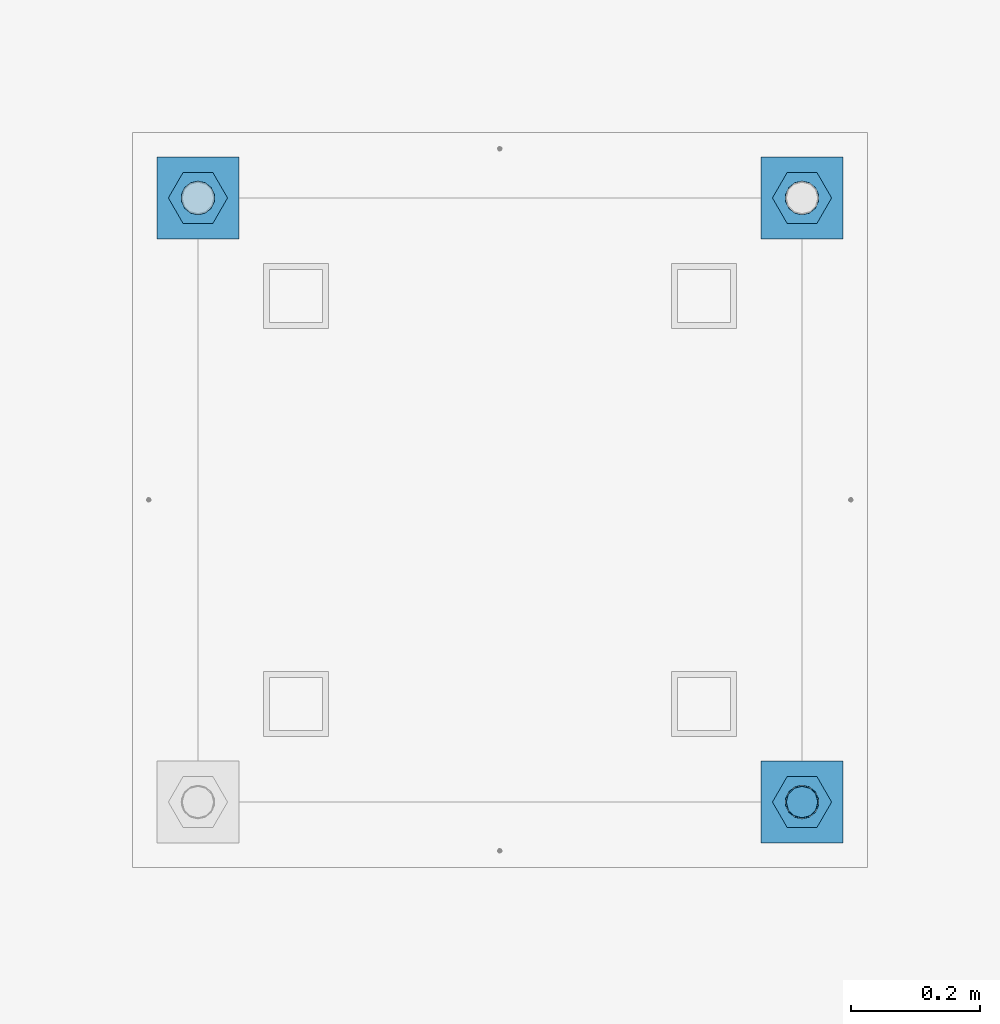
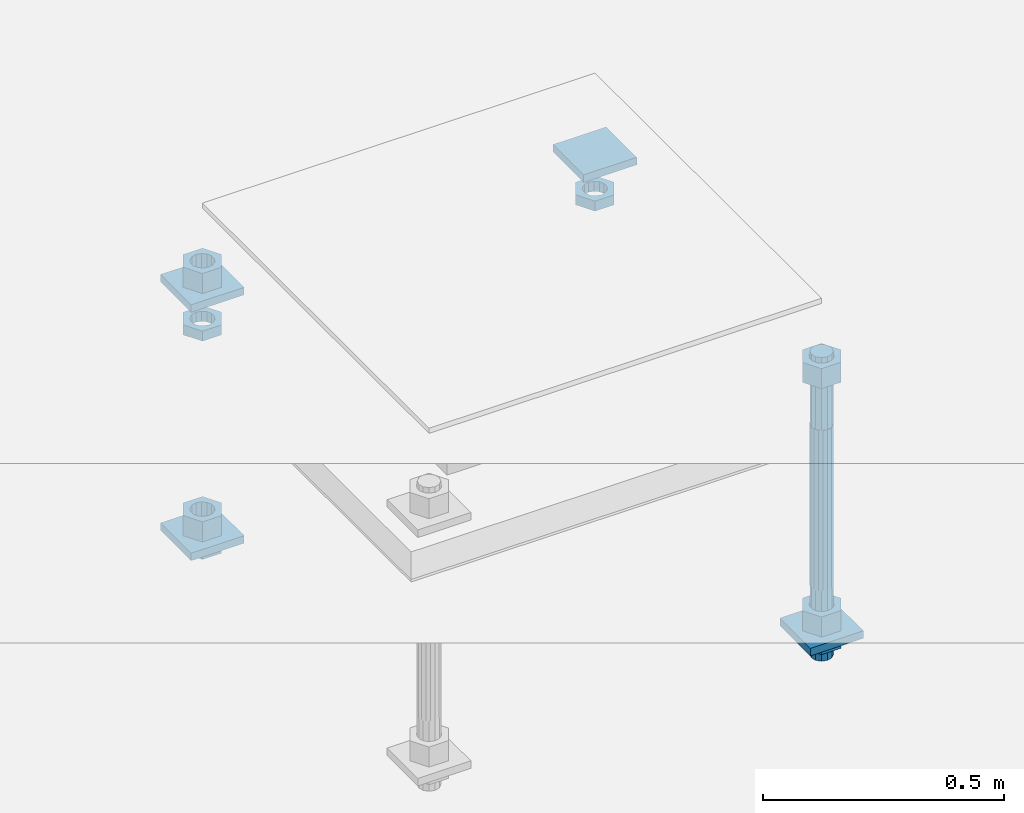
# One storey, part 2688 of 3843: 13 beams, 1 element without a shape of its own.
"""IFC2X3 building model written with IfcOpenShell, lengths in millimetres."""

import ifcopenshell
import ifcopenshell.guid

model = None  # the IFC model being written
_history = None  # IfcOwnerHistory: only IFC2X3 demands one
_inside = {}  # id of a spatial element -> (the spatial element, [elements in it])
_under = {}  # id of a project, library or spatial element -> (it, [spatial elements below it])
_declared = {}  # id of a project -> (the project, [libraries it declares])
_typed = {}  # id of a type object -> (the type object, [elements of that type])
_made_of = {}  # id of a material, layer set ... -> (it, [elements and type objects made of it])


def new_model(schema):
    """Start an empty IFC model of exactly this schema.

    Asked for "IFC4X3", IfcOpenShell would pick the latest addendum, in which some entities
    have other attributes; the version numbers below select the first issue.
    IFC2X3 requires an IfcOwnerHistory on every rooted entity: one is made here for all.
    """
    global model, _history
    if schema == "IFC4X3":
        model = ifcopenshell.file(schema_version=(4, 3, 0, 0))
    else:
        model = ifcopenshell.file(schema=schema)
    _inside.clear()
    _under.clear()
    _declared.clear()
    _typed.clear()
    _made_of.clear()
    _history = None
    if model.schema == "IFC2X3":
        org = make("IfcOrganization", Name="unknown")
        user = make(
            "IfcPersonAndOrganization",
            ThePerson=make("IfcPerson", FamilyName="unknown"),
            TheOrganization=org,
        )
        app = make(
            "IfcApplication",
            ApplicationDeveloper=org,
            Version="unknown",
            ApplicationFullName="unknown",
            ApplicationIdentifier="unknown",
        )
        _history = make(
            "IfcOwnerHistory",
            OwningUser=user,
            OwningApplication=app,
            ChangeAction="ADDED",
            CreationDate=0,
        )
    return model


def make(cls, **values):
    """One entity of the class cls with the attributes given. An attribute that is None is left unset."""
    return model.create_entity(
        cls, **{name: value for name, value in values.items() if value is not None}
    )


def rooted(cls, **values):
    """An entity with a GlobalId (a new one), such as an element, a storey or a relation."""
    return make(cls, GlobalId=ifcopenshell.guid.new(), OwnerHistory=_history, **values)


def si_unit(unit_type, name, prefix=None):
    """IfcSIUnit, for example si_unit("LENGTHUNIT", "METRE", prefix="MILLI")."""
    return make("IfcSIUnit", UnitType=unit_type, Prefix=prefix, Name=name)


def assignment(units):
    """IfcUnitAssignment: the units of a project."""
    return None if units is None else make("IfcUnitAssignment", Units=units)


def point(xyz):
    """IfcCartesianPoint."""
    return None if xyz is None else make("IfcCartesianPoint", Coordinates=xyz)


def direction(xyz):
    """IfcDirection."""
    return None if xyz is None else make("IfcDirection", DirectionRatios=xyz)


def frame(location, z_axis=None, x_axis=None):
    """IfcAxis2Placement3D, a coordinate frame: its origin and axes. An axis left out is left unset."""
    return make(
        "IfcAxis2Placement3D",
        Location=point(location),
        Axis=direction(z_axis),
        RefDirection=direction(x_axis),
    )


def origin_with_axes():
    """The frame at (0, 0, 0) with the z axis (0, 0, 1) and the x axis (1, 0, 0) written out."""
    return frame((0.0, 0.0, 0.0), z_axis=(0.0, 0.0, 1.0), x_axis=(1.0, 0.0, 0.0))


def place(relative_to, where):
    """IfcLocalPlacement: puts the frame where relative to a parent placement (None: the world)."""
    return make(
        "IfcLocalPlacement", PlacementRelTo=relative_to, RelativePlacement=where
    )


def context(
    kind, dimensions, precision=None, world=None, true_north=None, identifier=None
):
    """IfcGeometricRepresentationContext, for example the 3D "Model" context."""
    return make(
        "IfcGeometricRepresentationContext",
        ContextIdentifier=identifier,
        ContextType=kind,
        CoordinateSpaceDimension=dimensions,
        Precision=precision,
        WorldCoordinateSystem=world,
        TrueNorth=true_north,
    )


def subcontext(parent, identifier, kind, view, scale=None):
    """IfcGeometricRepresentationSubContext, for example "Body" below "Model"."""
    return make(
        "IfcGeometricRepresentationSubContext",
        ContextIdentifier=identifier,
        ContextType=kind,
        ParentContext=parent,
        TargetScale=scale,
        TargetView=view,
    )


def project(units=None, contexts=None):
    """IfcProject with its units and contexts."""
    return rooted(
        "IfcProject",
        Name="project",
        RepresentationContexts=contexts,
        UnitsInContext=assignment(units),
    )


def spatial(cls, under=None, at=None, **own):
    """A site, building, storey or space (cls), placed at a placement, below another one or the project."""
    s = rooted(cls, ObjectPlacement=at, **own)
    if under is not None:
        _under.setdefault(under.id(), (under, []))[1].append(s)
    return s


def faces_of(points, faces, orient=None, outer=None):
    """IfcFace entities. A face is a list of loops; a loop is a list of indices into points, from 0.

    orient and outer hold one flag for each loop. By default every Orientation is true, the
    first loop of a face is its IfcFaceOuterBound and the others are IfcFaceBound.
    """
    made = []
    for i, loops in enumerate(faces):
        bounds = []
        for j, loop in enumerate(loops):
            is_outer = j == 0 if outer is None else outer[i][j]
            bounds.append(
                make(
                    "IfcFaceOuterBound" if is_outer else "IfcFaceBound",
                    Bound=make("IfcPolyLoop", Polygon=[points[k] for k in loop]),
                    Orientation=True if orient is None else orient[i][j],
                )
            )
        made.append(make("IfcFace", Bounds=bounds))
    return made


def faceted_brep(points, faces, orient=None, outer=None, voids=None):
    """IfcFacetedBrep: a solid bounded by flat faces; with voids (closed shells), ...WithVoids."""
    shared = [point(p) for p in points]
    hull = make("IfcClosedShell", CfsFaces=faces_of(shared, faces, orient, outer))
    if voids is None:
        return make("IfcFacetedBrep", Outer=hull)
    return make(
        "IfcFacetedBrepWithVoids",
        Outer=hull,
        Voids=[
            make(cls, CfsFaces=faces_of(shared, fs, o, b)) for cls, fs, o, b in voids
        ],
    )


def shape(context_of_items, identifier, shape_type, items):
    """IfcShapeRepresentation: the items that make up one representation, for example the "Body"."""
    return make(
        "IfcShapeRepresentation",
        ContextOfItems=context_of_items,
        RepresentationIdentifier=identifier,
        RepresentationType=shape_type,
        Items=items,
    )


def material(Name=None, Category=None):
    """IfcMaterial."""
    return make("IfcMaterial", Name=Name, Category=Category)


def made_of(thing, what):
    """Note that an element or type object is made of a material, layer set ...; save() writes the relation."""
    if what is not None:
        _made_of.setdefault(what.id(), (what, []))[1].append(thing)
    return thing


def type_object(cls, material=None, **own):
    """A type object (cls), such as IfcWallType, which elements share."""
    return made_of(rooted(cls, **own), material)


def element(
    cls,
    number,
    at=None,
    inside=None,
    cuts=None,
    type_object=None,
    material=None,
    context=None,
    identifier="Body",
    shape_type=None,
    held_by="IfcProductDefinitionShape",
    body=None,
    shapes=None,
    **own,
):
    """One element of the class cls, such as IfcWall. Its Tag is "e" and its number.

    at: its placement. inside: the storey or other place that contains it. cuts: it is an
    opening in that element (IfcRelVoidsElement). A single representation is given by context,
    identifier, shape_type and body (its items); several are given by shapes. held_by: the class
    of the entity that holds the representations. save() writes the other relations.
    """
    e = rooted(cls, Tag="e%d" % number, ObjectPlacement=at, **own)
    if body is not None:
        shapes = [shape(context, identifier, shape_type, body)]
    if shapes is not None:
        e.Representation = make(held_by, Representations=shapes)
    if inside is not None:
        _inside.setdefault(inside.id(), (inside, []))[1].append(e)
    if cuts is not None:
        rooted(
            "IfcRelVoidsElement", RelatingBuildingElement=cuts, RelatedOpeningElement=e
        )
    if type_object is not None:
        _typed.setdefault(type_object.id(), (type_object, []))[1].append(e)
    return made_of(e, material)


def aggregate(whole, parts):
    """IfcRelAggregates: a whole, such as a stair, and the parts it consists of."""
    return rooted("IfcRelAggregates", RelatingObject=whole, RelatedObjects=parts)


def save(model, path):
    """Write the relations noted so far, then the file.

    IfcRelAggregates (storeys below a building ...), IfcRelContainedInSpatialStructure (elements
    in a storey), IfcRelDefinesByType, IfcRelAssociatesMaterial and IfcRelDeclares: one each for
    every whole, place, type object, material and project.
    """
    for whole, parts in _under.values():
        aggregate(whole, parts)
    for where, things in _inside.values():
        rooted(
            "IfcRelContainedInSpatialStructure",
            RelatedElements=things,
            RelatingStructure=where,
        )
    for kind, things in _typed.values():
        rooted("IfcRelDefinesByType", RelatedObjects=things, RelatingType=kind)
    for what, things in _made_of.values():
        rooted("IfcRelAssociatesMaterial", RelatedObjects=things, RelatingMaterial=what)
    for by, libraries in _declared.values():
        rooted("IfcRelDeclares", RelatingContext=by, RelatedDefinitions=libraries)
    model.write(path)


model = new_model("IFC2X3")

# Units and contexts
model_context = context("Model", 3, precision=1e-05, world=origin_with_axes())
body_context = subcontext(model_context, "Body", "Model", "MODEL_VIEW")
ifc_project = project(units=[si_unit("LENGTHUNIT", "METRE", prefix="MILLI"), si_unit("AREAUNIT", "SQUARE_METRE"), si_unit("VOLUMEUNIT", "CUBIC_METRE"), si_unit("MASSUNIT", "GRAM", prefix="KILO"), si_unit("TIMEUNIT", "SECOND"), si_unit("PLANEANGLEUNIT", "RADIAN"), si_unit("SOLIDANGLEUNIT", "STERADIAN"), si_unit("THERMODYNAMICTEMPERATUREUNIT", "DEGREE_CELSIUS"), si_unit("LUMINOUSINTENSITYUNIT", "LUMEN")], contexts=[model_context])

# Site, building, storey
site_placement = place(None, origin_with_axes())
site = spatial("IfcSite", under=ifc_project, at=site_placement, CompositionType="ELEMENT")
building_placement = place(site_placement, origin_with_axes())
building = spatial("IfcBuilding", under=site, at=building_placement, Name="Undefined", CompositionType="ELEMENT")
storey_placement = place(building_placement, origin_with_axes())
storey = spatial("IfcBuildingStorey", under=building, at=storey_placement, Name="Undefined", CompositionType="ELEMENT", Elevation=0.0)

# Assembly, beams
assembly_placement = place(storey_placement, origin_with_axes())
assembly = element("IfcElementAssembly", 1, at=assembly_placement, inside=storey, Name="TEMPLATE", AssemblyPlace="NOTDEFINED", PredefinedType="RIGID_FRAME")
ifc_material_1 = material(Name="STEEL/A36")
beam_type_1 = type_object("IfcBeamType", PredefinedType="NOTDEFINED")
beam_1_placement = place(assembly_placement, frame((108483.4, 32867.6000015259, 29873.575), z_axis=(1.0, 0.0, 0.0), x_axis=(0.0, 1.0, 0.0)))
beam_1 = element("IfcBeam", 2, at=beam_1_placement, type_object=beam_type_1, material=ifc_material_1, Name="WASHER_PLATE", context=body_context, shape_type="Brep", body=[
    faceted_brep([(0.0, 9.52500000000146, -63.5), (0.0, 9.52500000000146, 63.5), (127.0, 9.52500000000146, 63.5), (127.0, 9.52500000000146, -63.5), (0.0, -9.52500000000146, 63.5), (127.0, -9.52500000000146, 63.5), (0.0, -9.52500000000146, -63.5), (127.0, -9.52500000000146, -63.5)], [[[0, 1, 2, 3]], [[1, 4, 5, 2]], [[4, 6, 7, 5]], [[6, 0, 3, 7]], [[5, 7, 3, 2]], [[6, 4, 1, 0]]]),
])
beam_2_placement = place(assembly_placement, frame((109423.2, 32867.6000015259, 29873.575), z_axis=(1.0, 0.0, 0.0), x_axis=(0.0, 1.0, 0.0)))
beam_2 = element("IfcBeam", 3, at=beam_2_placement, type_object=beam_type_1, material=ifc_material_1, Name="WASHER_PLATE", context=body_context, shape_type="Brep", body=[
    faceted_brep([(0.0, 9.52500000000146, -63.5), (0.0, 9.52500000000146, 63.5), (127.0, 9.52500000000146, 63.5), (127.0, 9.52500000000146, -63.5), (0.0, -9.52500000000146, 63.5), (127.0, -9.52500000000146, 63.5), (0.0, -9.52500000000146, -63.5), (127.0, -9.52500000000146, -63.5)], [[[0, 1, 2, 3]], [[1, 4, 5, 2]], [[4, 6, 7, 5]], [[6, 0, 3, 7]], [[5, 7, 3, 2]], [[6, 4, 1, 0]]]),
])
beam_3_placement = place(assembly_placement, frame((109423.2, 31927.8000015259, 29244.925), z_axis=(1.0, 0.0, 0.0), x_axis=(0.0, 1.0, 0.0)))
beam_3 = element("IfcBeam", 4, at=beam_3_placement, type_object=beam_type_1, material=ifc_material_1, Name="WASHER_PLATE", context=body_context, shape_type="Brep", body=[
    faceted_brep([(0.0, 9.52500000000146, -63.5), (0.0, 9.52500000000146, 63.5), (127.0, 9.52500000000146, 63.5), (127.0, 9.52500000000146, -63.5), (0.0, -9.52500000000146, 63.5), (127.0, -9.52500000000146, 63.5), (0.0, -9.52500000000146, -63.5), (127.0, -9.52500000000146, -63.5)], [[[0, 1, 2, 3]], [[1, 4, 5, 2]], [[4, 6, 7, 5]], [[6, 0, 3, 7]], [[5, 7, 3, 2]], [[6, 4, 1, 0]]]),
])
beam_4_placement = place(assembly_placement, frame((108483.4, 32867.6000015259, 29244.925), z_axis=(1.0, 0.0, 0.0), x_axis=(0.0, 1.0, 0.0)))
beam_4 = element("IfcBeam", 5, at=beam_4_placement, type_object=beam_type_1, material=ifc_material_1, Name="WASHER_PLATE", context=body_context, shape_type="Brep", body=[
    faceted_brep([(0.0, 9.52500000000146, -63.5), (0.0, 9.52500000000146, 63.5), (127.0, 9.52500000000146, 63.5), (127.0, 9.52500000000146, -63.5), (0.0, -9.52500000000146, 63.5), (127.0, -9.52500000000146, 63.5), (0.0, -9.52500000000146, -63.5), (127.0, -9.52500000000146, -63.5)], [[[0, 1, 2, 3]], [[1, 4, 5, 2]], [[4, 6, 7, 5]], [[6, 0, 3, 7]], [[5, 7, 3, 2]], [[6, 4, 1, 0]]]),
])
beam_type_2 = type_object("IfcBeamType", Name="2_HALF_NUT", PredefinedType="NOTDEFINED")
beam_5_placement = place(assembly_placement, frame((108483.4, 32931.1000015259, 29787.85), z_axis=(0.0, -1.0, 0.0), x_axis=(0.0, 0.0, -1.0)))
beam_5 = element("IfcBeam", 6, at=beam_5_placement, type_object=beam_type_2, material=ifc_material_1, Name="NUT", ObjectType="2_HALF_NUT", context=body_context, shape_type="Brep", body=[
    faceted_brep([(0.0, -46.0369987487793, 0.0), (0.0, -23.0184993743896, -39.869213104248), (25.4000000000015, -23.0184993743896, -39.869213104248), (25.4000000000015, -46.0369987487793, 0.0), (0.0, 23.0184993743896, -39.869213104248), (25.4000000000015, 23.0184993743896, -39.869213104248), (0.0, 46.0369987487793, 0.0), (25.4000000000015, 46.0369987487793, 0.0), (0.0, 23.0184993743896, 39.869213104248), (25.4000000000015, 23.0184993743896, 39.869213104248), (0.0, -23.0184993743896, 39.869213104248), (25.4000000000015, -23.0184993743896, 39.869213104248), (0.0, 0.0, 26.1940002441406), (0.0, 11.3650617044477, 23.5999013092805), (25.4000000000015, 11.3650617044477, 23.5999013092805), (25.4000000000015, 0.0, 26.1940002441406), (0.0, 20.4791109456419, 16.3316083006721), (25.4000000000015, 20.4791109456419, 16.3316083006721), (0.0, 25.5370200498292, 5.82867859874386), (25.4000000000015, 25.5370200498292, 5.82867859874386), (0.0, 25.5370200498292, -5.82867859874386), (25.4000000000015, 25.5370200498292, -5.82867859874386), (0.0, 20.4791109456419, -16.3316083006721), (25.4000000000015, 20.4791109456419, -16.3316083006721), (0.0, 11.3650617044477, -23.5999013092805), (25.4000000000015, 11.3650617044477, -23.5999013092805), (0.0, 0.0, -26.1940002441406), (25.4000000000015, 0.0, -26.1940002441406), (0.0, -11.3650617044477, -23.5999013092805), (25.4000000000015, -11.3650617044477, -23.5999013092805), (0.0, -20.4791109456419, -16.3316083006721), (25.4000000000015, -20.4791109456419, -16.3316083006721), (0.0, -25.5370200498292, -5.82867859874386), (25.4000000000015, -25.5370200498292, -5.82867859874386), (0.0, -25.5370200498292, 5.82867859874386), (25.4000000000015, -25.5370200498292, 5.82867859874386), (0.0, -20.4791109456419, 16.3316083006721), (25.4000000000015, -20.4791109456419, 16.3316083006721), (0.0, -11.3650617044477, 23.5999013092805), (25.4000000000015, -11.3650617044477, 23.5999013092805)], [[[0, 1, 2, 3]], [[1, 4, 5, 2]], [[4, 6, 7, 5]], [[6, 8, 9, 7]], [[8, 10, 11, 9]], [[10, 0, 3, 11]], [[12, 13, 14, 15]], [[13, 16, 17, 14]], [[16, 18, 19, 17]], [[18, 20, 21, 19]], [[20, 22, 23, 21]], [[22, 24, 25, 23]], [[24, 26, 27, 25]], [[26, 28, 29, 27]], [[28, 30, 31, 29]], [[30, 32, 33, 31]], [[32, 34, 35, 33]], [[34, 36, 37, 35]], [[36, 38, 39, 37]], [[38, 12, 15, 39]], [[5, 7, 9, 11, 3, 2], [17, 19, 21, 23, 25, 27, 29, 31, 33, 35, 37, 39, 15, 14]], [[10, 8, 6, 4, 1, 0], [38, 36, 34, 32, 30, 28, 26, 24, 22, 20, 18, 16, 13, 12]]]),
])
beam_6_placement = place(assembly_placement, frame((109423.2, 32931.1000015259, 29787.85), z_axis=(0.0, 1.0, 0.0), x_axis=(0.0, 0.0, -1.0)))
beam_6 = element("IfcBeam", 7, at=beam_6_placement, type_object=beam_type_2, material=ifc_material_1, Name="NUT", ObjectType="2_HALF_NUT", context=body_context, shape_type="Brep", body=[
    faceted_brep([(0.0, -46.0369987487793, 0.0), (0.0, -23.0184993743896, -39.869213104248), (25.4000000000015, -23.0184993743896, -39.869213104248), (25.4000000000015, -46.0369987487793, 0.0), (0.0, 23.0184993743896, -39.869213104248), (25.4000000000015, 23.0184993743896, -39.869213104248), (0.0, 46.0369987487793, 0.0), (25.4000000000015, 46.0369987487793, 0.0), (0.0, 23.0184993743896, 39.869213104248), (25.4000000000015, 23.0184993743896, 39.869213104248), (0.0, -23.0184993743896, 39.869213104248), (25.4000000000015, -23.0184993743896, 39.869213104248), (0.0, 0.0, 26.1940002441406), (0.0, 11.3650617044477, 23.5999013092805), (25.4000000000015, 11.3650617044477, 23.5999013092805), (25.4000000000015, 0.0, 26.1940002441406), (0.0, 20.4791109456419, 16.3316083006721), (25.4000000000015, 20.4791109456419, 16.3316083006721), (0.0, 25.5370200498292, 5.82867859874386), (25.4000000000015, 25.5370200498292, 5.82867859874386), (0.0, 25.5370200498292, -5.82867859874386), (25.4000000000015, 25.5370200498292, -5.82867859874386), (0.0, 20.4791109456419, -16.3316083006721), (25.4000000000015, 20.4791109456419, -16.3316083006721), (0.0, 11.3650617044477, -23.5999013092805), (25.4000000000015, 11.3650617044477, -23.5999013092805), (0.0, 0.0, -26.1940002441406), (25.4000000000015, 0.0, -26.1940002441406), (0.0, -11.3650617044477, -23.5999013092805), (25.4000000000015, -11.3650617044477, -23.5999013092805), (0.0, -20.4791109456419, -16.3316083006721), (25.4000000000015, -20.4791109456419, -16.3316083006721), (0.0, -25.5370200498292, -5.82867859874386), (25.4000000000015, -25.5370200498292, -5.82867859874386), (0.0, -25.5370200498292, 5.82867859874386), (25.4000000000015, -25.5370200498292, 5.82867859874386), (0.0, -20.4791109456419, 16.3316083006721), (25.4000000000015, -20.4791109456419, 16.3316083006721), (0.0, -11.3650617044477, 23.5999013092805), (25.4000000000015, -11.3650617044477, 23.5999013092805)], [[[0, 1, 2, 3]], [[1, 4, 5, 2]], [[4, 6, 7, 5]], [[6, 8, 9, 7]], [[8, 10, 11, 9]], [[10, 0, 3, 11]], [[12, 13, 14, 15]], [[13, 16, 17, 14]], [[16, 18, 19, 17]], [[18, 20, 21, 19]], [[20, 22, 23, 21]], [[22, 24, 25, 23]], [[24, 26, 27, 25]], [[26, 28, 29, 27]], [[28, 30, 31, 29]], [[30, 32, 33, 31]], [[32, 34, 35, 33]], [[34, 36, 37, 35]], [[36, 38, 39, 37]], [[38, 12, 15, 39]], [[5, 7, 9, 11, 3, 2], [17, 19, 21, 23, 25, 27, 29, 31, 33, 35, 37, 39, 15, 14]], [[10, 8, 6, 4, 1, 0], [38, 36, 34, 32, 30, 28, 26, 24, 22, 20, 18, 16, 13, 12]]]),
])
beam_7_placement = place(assembly_placement, frame((109423.2, 31991.3000015259, 29235.4), z_axis=(0.0, 1.0, 0.0), x_axis=(0.0, 0.0, -1.0)))
beam_7 = element("IfcBeam", 8, at=beam_7_placement, type_object=beam_type_2, material=ifc_material_1, Name="NUT", ObjectType="2_HALF_NUT", context=body_context, shape_type="Brep", body=[
    faceted_brep([(0.0, -46.0369987487793, 0.0), (0.0, -23.0184993743896, -39.869213104248), (25.4000000000015, -23.0184993743896, -39.869213104248), (25.4000000000015, -46.0369987487793, 0.0), (0.0, 23.0184993743896, -39.869213104248), (25.4000000000015, 23.0184993743896, -39.869213104248), (0.0, 46.0369987487793, 0.0), (25.4000000000015, 46.0369987487793, 0.0), (0.0, 23.0184993743896, 39.869213104248), (25.4000000000015, 23.0184993743896, 39.869213104248), (0.0, -23.0184993743896, 39.869213104248), (25.4000000000015, -23.0184993743896, 39.869213104248), (0.0, 0.0, 26.1940002441406), (0.0, 11.3650617044477, 23.5999013092805), (25.4000000000015, 11.3650617044477, 23.5999013092805), (25.4000000000015, 0.0, 26.1940002441406), (0.0, 20.4791109456419, 16.3316083006721), (25.4000000000015, 20.4791109456419, 16.3316083006721), (0.0, 25.5370200498292, 5.82867859874386), (25.4000000000015, 25.5370200498292, 5.82867859874386), (0.0, 25.5370200498292, -5.82867859874386), (25.4000000000015, 25.5370200498292, -5.82867859874386), (0.0, 20.4791109456419, -16.3316083006721), (25.4000000000015, 20.4791109456419, -16.3316083006721), (0.0, 11.3650617044477, -23.5999013092805), (25.4000000000015, 11.3650617044477, -23.5999013092805), (0.0, 0.0, -26.1940002441406), (25.4000000000015, 0.0, -26.1940002441406), (0.0, -11.3650617044477, -23.5999013092805), (25.4000000000015, -11.3650617044477, -23.5999013092805), (0.0, -20.4791109456419, -16.3316083006721), (25.4000000000015, -20.4791109456419, -16.3316083006721), (0.0, -25.5370200498292, -5.82867859874386), (25.4000000000015, -25.5370200498292, -5.82867859874386), (0.0, -25.5370200498292, 5.82867859874386), (25.4000000000015, -25.5370200498292, 5.82867859874386), (0.0, -20.4791109456419, 16.3316083006721), (25.4000000000015, -20.4791109456419, 16.3316083006721), (0.0, -11.3650617044477, 23.5999013092805), (25.4000000000015, -11.3650617044477, 23.5999013092805)], [[[0, 1, 2, 3]], [[1, 4, 5, 2]], [[4, 6, 7, 5]], [[6, 8, 9, 7]], [[8, 10, 11, 9]], [[10, 0, 3, 11]], [[12, 13, 14, 15]], [[13, 16, 17, 14]], [[16, 18, 19, 17]], [[18, 20, 21, 19]], [[20, 22, 23, 21]], [[22, 24, 25, 23]], [[24, 26, 27, 25]], [[26, 28, 29, 27]], [[28, 30, 31, 29]], [[30, 32, 33, 31]], [[32, 34, 35, 33]], [[34, 36, 37, 35]], [[36, 38, 39, 37]], [[38, 12, 15, 39]], [[5, 7, 9, 11, 3, 2], [17, 19, 21, 23, 25, 27, 29, 31, 33, 35, 37, 39, 15, 14]], [[10, 8, 6, 4, 1, 0], [38, 36, 34, 32, 30, 28, 26, 24, 22, 20, 18, 16, 13, 12]]]),
])
beam_8_placement = place(assembly_placement, frame((108483.4, 32931.1000015259, 29235.4), z_axis=(0.0, -1.0, 0.0), x_axis=(0.0, 0.0, -1.0)))
beam_8 = element("IfcBeam", 9, at=beam_8_placement, type_object=beam_type_2, material=ifc_material_1, Name="NUT", ObjectType="2_HALF_NUT", context=body_context, shape_type="Brep", body=[
    faceted_brep([(0.0, -46.0369987487793, 0.0), (0.0, -23.0184993743896, -39.869213104248), (25.4000000000015, -23.0184993743896, -39.869213104248), (25.4000000000015, -46.0369987487793, 0.0), (0.0, 23.0184993743896, -39.869213104248), (25.4000000000015, 23.0184993743896, -39.869213104248), (0.0, 46.0369987487793, 0.0), (25.4000000000015, 46.0369987487793, 0.0), (0.0, 23.0184993743896, 39.869213104248), (25.4000000000015, 23.0184993743896, 39.869213104248), (0.0, -23.0184993743896, 39.869213104248), (25.4000000000015, -23.0184993743896, 39.869213104248), (0.0, 0.0, 26.1940002441406), (0.0, 11.3650617044477, 23.5999013092805), (25.4000000000015, 11.3650617044477, 23.5999013092805), (25.4000000000015, 0.0, 26.1940002441406), (0.0, 20.4791109456419, 16.3316083006721), (25.4000000000015, 20.4791109456419, 16.3316083006721), (0.0, 25.5370200498292, 5.82867859874386), (25.4000000000015, 25.5370200498292, 5.82867859874386), (0.0, 25.5370200498292, -5.82867859874386), (25.4000000000015, 25.5370200498292, -5.82867859874386), (0.0, 20.4791109456419, -16.3316083006721), (25.4000000000015, 20.4791109456419, -16.3316083006721), (0.0, 11.3650617044477, -23.5999013092805), (25.4000000000015, 11.3650617044477, -23.5999013092805), (0.0, 0.0, -26.1940002441406), (25.4000000000015, 0.0, -26.1940002441406), (0.0, -11.3650617044477, -23.5999013092805), (25.4000000000015, -11.3650617044477, -23.5999013092805), (0.0, -20.4791109456419, -16.3316083006721), (25.4000000000015, -20.4791109456419, -16.3316083006721), (0.0, -25.5370200498292, -5.82867859874386), (25.4000000000015, -25.5370200498292, -5.82867859874386), (0.0, -25.5370200498292, 5.82867859874386), (25.4000000000015, -25.5370200498292, 5.82867859874386), (0.0, -20.4791109456419, 16.3316083006721), (25.4000000000015, -20.4791109456419, 16.3316083006721), (0.0, -11.3650617044477, 23.5999013092805), (25.4000000000015, -11.3650617044477, 23.5999013092805)], [[[0, 1, 2, 3]], [[1, 4, 5, 2]], [[4, 6, 7, 5]], [[6, 8, 9, 7]], [[8, 10, 11, 9]], [[10, 0, 3, 11]], [[12, 13, 14, 15]], [[13, 16, 17, 14]], [[16, 18, 19, 17]], [[18, 20, 21, 19]], [[20, 22, 23, 21]], [[22, 24, 25, 23]], [[24, 26, 27, 25]], [[26, 28, 29, 27]], [[28, 30, 31, 29]], [[30, 32, 33, 31]], [[32, 34, 35, 33]], [[34, 36, 37, 35]], [[36, 38, 39, 37]], [[38, 12, 15, 39]], [[5, 7, 9, 11, 3, 2], [17, 19, 21, 23, 25, 27, 29, 31, 33, 35, 37, 39, 15, 14]], [[10, 8, 6, 4, 1, 0], [38, 36, 34, 32, 30, 28, 26, 24, 22, 20, 18, 16, 13, 12]]]),
])
beam_type_3 = type_object("IfcBeamType", Name="2_HEAVY_HEX_NUT", PredefinedType="NOTDEFINED")
beam_9_placement = place(assembly_placement, frame((109423.2, 31991.3000015259, 29933.9), z_axis=(0.0, 1.0, 0.0), x_axis=(0.0, 0.0, -1.0)))
beam_9 = element("IfcBeam", 10, at=beam_9_placement, type_object=beam_type_3, material=ifc_material_1, Name="NUT", ObjectType="2_HEAVY_HEX_NUT", context=body_context, shape_type="Brep", body=[
    faceted_brep([(0.0, -46.0369987487793, 0.0), (0.0, -23.0184993743896, -39.869213104248), (50.7999999999993, -23.0184993743896, -39.869213104248), (50.7999999999993, -46.0369987487793, 0.0), (0.0, 23.0184993743896, -39.869213104248), (50.7999999999993, 23.0184993743896, -39.869213104248), (0.0, 46.0369987487793, 0.0), (50.7999999999993, 46.0369987487793, 0.0), (0.0, 23.0184993743896, 39.869213104248), (50.7999999999993, 23.0184993743896, 39.869213104248), (0.0, -23.0184993743896, 39.869213104248), (50.7999999999993, -23.0184993743896, 39.869213104248), (0.0, 0.0, 26.1940002441406), (0.0, 11.3650617044477, 23.5999013092805), (50.7999999999993, 11.3650617044477, 23.5999013092805), (50.7999999999993, 0.0, 26.1940002441406), (0.0, 20.4791109456419, 16.3316083006721), (50.7999999999993, 20.4791109456419, 16.3316083006721), (0.0, 25.5370200498292, 5.82867859874386), (50.7999999999993, 25.5370200498292, 5.82867859874386), (0.0, 25.5370200498292, -5.82867859874386), (50.7999999999993, 25.5370200498292, -5.82867859874386), (0.0, 20.4791109456419, -16.3316083006721), (50.7999999999993, 20.4791109456419, -16.3316083006721), (0.0, 11.3650617044477, -23.5999013092805), (50.7999999999993, 11.3650617044477, -23.5999013092805), (0.0, 0.0, -26.1940002441406), (50.7999999999993, 0.0, -26.1940002441406), (0.0, -11.3650617044477, -23.5999013092805), (50.7999999999993, -11.3650617044477, -23.5999013092805), (0.0, -20.4791109456419, -16.3316083006721), (50.7999999999993, -20.4791109456419, -16.3316083006721), (0.0, -25.5370200498292, -5.82867859874386), (50.7999999999993, -25.5370200498292, -5.82867859874386), (0.0, -25.5370200498292, 5.82867859874386), (50.7999999999993, -25.5370200498292, 5.82867859874386), (0.0, -20.4791109456419, 16.3316083006721), (50.7999999999993, -20.4791109456419, 16.3316083006721), (0.0, -11.3650617044477, 23.5999013092805), (50.7999999999993, -11.3650617044477, 23.5999013092805)], [[[0, 1, 2, 3]], [[1, 4, 5, 2]], [[4, 6, 7, 5]], [[6, 8, 9, 7]], [[8, 10, 11, 9]], [[10, 0, 3, 11]], [[12, 13, 14, 15]], [[13, 16, 17, 14]], [[16, 18, 19, 17]], [[18, 20, 21, 19]], [[20, 22, 23, 21]], [[22, 24, 25, 23]], [[24, 26, 27, 25]], [[26, 28, 29, 27]], [[28, 30, 31, 29]], [[30, 32, 33, 31]], [[32, 34, 35, 33]], [[34, 36, 37, 35]], [[36, 38, 39, 37]], [[38, 12, 15, 39]], [[5, 7, 9, 11, 3, 2], [17, 19, 21, 23, 25, 27, 29, 31, 33, 35, 37, 39, 15, 14]], [[10, 8, 6, 4, 1, 0], [38, 36, 34, 32, 30, 28, 26, 24, 22, 20, 18, 16, 13, 12]]]),
])
beam_10_placement = place(assembly_placement, frame((109423.2, 31991.3000015259, 29305.25), z_axis=(0.0, 1.0, 0.0), x_axis=(0.0, 0.0, -1.0)))
beam_10 = element("IfcBeam", 11, at=beam_10_placement, type_object=beam_type_3, material=ifc_material_1, Name="NUT", ObjectType="2_HEAVY_HEX_NUT", context=body_context, shape_type="Brep", body=[
    faceted_brep([(0.0, -46.0369987487793, 0.0), (0.0, -23.0184993743896, -39.869213104248), (50.7999999999993, -23.0184993743896, -39.869213104248), (50.7999999999993, -46.0369987487793, 0.0), (0.0, 23.0184993743896, -39.869213104248), (50.7999999999993, 23.0184993743896, -39.869213104248), (0.0, 46.0369987487793, 0.0), (50.7999999999993, 46.0369987487793, 0.0), (0.0, 23.0184993743896, 39.869213104248), (50.7999999999993, 23.0184993743896, 39.869213104248), (0.0, -23.0184993743896, 39.869213104248), (50.7999999999993, -23.0184993743896, 39.869213104248), (0.0, 0.0, 26.1940002441406), (0.0, 11.3650617044477, 23.5999013092805), (50.7999999999993, 11.3650617044477, 23.5999013092805), (50.7999999999993, 0.0, 26.1940002441406), (0.0, 20.4791109456419, 16.3316083006721), (50.7999999999993, 20.4791109456419, 16.3316083006721), (0.0, 25.5370200498292, 5.82867859874386), (50.7999999999993, 25.5370200498292, 5.82867859874386), (0.0, 25.5370200498292, -5.82867859874386), (50.7999999999993, 25.5370200498292, -5.82867859874386), (0.0, 20.4791109456419, -16.3316083006721), (50.7999999999993, 20.4791109456419, -16.3316083006721), (0.0, 11.3650617044477, -23.5999013092805), (50.7999999999993, 11.3650617044477, -23.5999013092805), (0.0, 0.0, -26.1940002441406), (50.7999999999993, 0.0, -26.1940002441406), (0.0, -11.3650617044477, -23.5999013092805), (50.7999999999993, -11.3650617044477, -23.5999013092805), (0.0, -20.4791109456419, -16.3316083006721), (50.7999999999993, -20.4791109456419, -16.3316083006721), (0.0, -25.5370200498292, -5.82867859874386), (50.7999999999993, -25.5370200498292, -5.82867859874386), (0.0, -25.5370200498292, 5.82867859874386), (50.7999999999993, -25.5370200498292, 5.82867859874386), (0.0, -20.4791109456419, 16.3316083006721), (50.7999999999993, -20.4791109456419, 16.3316083006721), (0.0, -11.3650617044477, 23.5999013092805), (50.7999999999993, -11.3650617044477, 23.5999013092805)], [[[0, 1, 2, 3]], [[1, 4, 5, 2]], [[4, 6, 7, 5]], [[6, 8, 9, 7]], [[8, 10, 11, 9]], [[10, 0, 3, 11]], [[12, 13, 14, 15]], [[13, 16, 17, 14]], [[16, 18, 19, 17]], [[18, 20, 21, 19]], [[20, 22, 23, 21]], [[22, 24, 25, 23]], [[24, 26, 27, 25]], [[26, 28, 29, 27]], [[28, 30, 31, 29]], [[30, 32, 33, 31]], [[32, 34, 35, 33]], [[34, 36, 37, 35]], [[36, 38, 39, 37]], [[38, 12, 15, 39]], [[5, 7, 9, 11, 3, 2], [17, 19, 21, 23, 25, 27, 29, 31, 33, 35, 37, 39, 15, 14]], [[10, 8, 6, 4, 1, 0], [38, 36, 34, 32, 30, 28, 26, 24, 22, 20, 18, 16, 13, 12]]]),
])
beam_11_placement = place(assembly_placement, frame((108483.4, 32931.1000015259, 29933.9), z_axis=(0.0, -1.0, 0.0), x_axis=(0.0, 0.0, -1.0)))
beam_11 = element("IfcBeam", 12, at=beam_11_placement, type_object=beam_type_3, material=ifc_material_1, Name="NUT", ObjectType="2_HEAVY_HEX_NUT", context=body_context, shape_type="Brep", body=[
    faceted_brep([(0.0, -46.0369987487793, 0.0), (0.0, -23.0184993743896, -39.869213104248), (50.7999999999993, -23.0184993743896, -39.869213104248), (50.7999999999993, -46.0369987487793, 0.0), (0.0, 23.0184993743896, -39.869213104248), (50.7999999999993, 23.0184993743896, -39.869213104248), (0.0, 46.0369987487793, 0.0), (50.7999999999993, 46.0369987487793, 0.0), (0.0, 23.0184993743896, 39.869213104248), (50.7999999999993, 23.0184993743896, 39.869213104248), (0.0, -23.0184993743896, 39.869213104248), (50.7999999999993, -23.0184993743896, 39.869213104248), (0.0, 0.0, 26.1940002441406), (0.0, 11.3650617044477, 23.5999013092805), (50.7999999999993, 11.3650617044477, 23.5999013092805), (50.7999999999993, 0.0, 26.1940002441406), (0.0, 20.4791109456419, 16.3316083006721), (50.7999999999993, 20.4791109456419, 16.3316083006721), (0.0, 25.5370200498292, 5.82867859874386), (50.7999999999993, 25.5370200498292, 5.82867859874386), (0.0, 25.5370200498292, -5.82867859874386), (50.7999999999993, 25.5370200498292, -5.82867859874386), (0.0, 20.4791109456419, -16.3316083006721), (50.7999999999993, 20.4791109456419, -16.3316083006721), (0.0, 11.3650617044477, -23.5999013092805), (50.7999999999993, 11.3650617044477, -23.5999013092805), (0.0, 0.0, -26.1940002441406), (50.7999999999993, 0.0, -26.1940002441406), (0.0, -11.3650617044477, -23.5999013092805), (50.7999999999993, -11.3650617044477, -23.5999013092805), (0.0, -20.4791109456419, -16.3316083006721), (50.7999999999993, -20.4791109456419, -16.3316083006721), (0.0, -25.5370200498292, -5.82867859874386), (50.7999999999993, -25.5370200498292, -5.82867859874386), (0.0, -25.5370200498292, 5.82867859874386), (50.7999999999993, -25.5370200498292, 5.82867859874386), (0.0, -20.4791109456419, 16.3316083006721), (50.7999999999993, -20.4791109456419, 16.3316083006721), (0.0, -11.3650617044477, 23.5999013092805), (50.7999999999993, -11.3650617044477, 23.5999013092805)], [[[0, 1, 2, 3]], [[1, 4, 5, 2]], [[4, 6, 7, 5]], [[6, 8, 9, 7]], [[8, 10, 11, 9]], [[10, 0, 3, 11]], [[12, 13, 14, 15]], [[13, 16, 17, 14]], [[16, 18, 19, 17]], [[18, 20, 21, 19]], [[20, 22, 23, 21]], [[22, 24, 25, 23]], [[24, 26, 27, 25]], [[26, 28, 29, 27]], [[28, 30, 31, 29]], [[30, 32, 33, 31]], [[32, 34, 35, 33]], [[34, 36, 37, 35]], [[36, 38, 39, 37]], [[38, 12, 15, 39]], [[5, 7, 9, 11, 3, 2], [17, 19, 21, 23, 25, 27, 29, 31, 33, 35, 37, 39, 15, 14]], [[10, 8, 6, 4, 1, 0], [38, 36, 34, 32, 30, 28, 26, 24, 22, 20, 18, 16, 13, 12]]]),
])
beam_12_placement = place(assembly_placement, frame((108483.4, 32931.1000015259, 29305.25), z_axis=(0.0, -1.0, 0.0), x_axis=(0.0, 0.0, -1.0)))
beam_12 = element("IfcBeam", 13, at=beam_12_placement, type_object=beam_type_3, material=ifc_material_1, Name="NUT", ObjectType="2_HEAVY_HEX_NUT", context=body_context, shape_type="Brep", body=[
    faceted_brep([(0.0, -46.0369987487793, 0.0), (0.0, -23.0184993743896, -39.869213104248), (50.7999999999993, -23.0184993743896, -39.869213104248), (50.7999999999993, -46.0369987487793, 0.0), (0.0, 23.0184993743896, -39.869213104248), (50.7999999999993, 23.0184993743896, -39.869213104248), (0.0, 46.0369987487793, 0.0), (50.7999999999993, 46.0369987487793, 0.0), (0.0, 23.0184993743896, 39.869213104248), (50.7999999999993, 23.0184993743896, 39.869213104248), (0.0, -23.0184993743896, 39.869213104248), (50.7999999999993, -23.0184993743896, 39.869213104248), (0.0, 0.0, 26.1940002441406), (0.0, 11.3650617044477, 23.5999013092805), (50.7999999999993, 11.3650617044477, 23.5999013092805), (50.7999999999993, 0.0, 26.1940002441406), (0.0, 20.4791109456419, 16.3316083006721), (50.7999999999993, 20.4791109456419, 16.3316083006721), (0.0, 25.5370200498292, 5.82867859874386), (50.7999999999993, 25.5370200498292, 5.82867859874386), (0.0, 25.5370200498292, -5.82867859874386), (50.7999999999993, 25.5370200498292, -5.82867859874386), (0.0, 20.4791109456419, -16.3316083006721), (50.7999999999993, 20.4791109456419, -16.3316083006721), (0.0, 11.3650617044477, -23.5999013092805), (50.7999999999993, 11.3650617044477, -23.5999013092805), (0.0, 0.0, -26.1940002441406), (50.7999999999993, 0.0, -26.1940002441406), (0.0, -11.3650617044477, -23.5999013092805), (50.7999999999993, -11.3650617044477, -23.5999013092805), (0.0, -20.4791109456419, -16.3316083006721), (50.7999999999993, -20.4791109456419, -16.3316083006721), (0.0, -25.5370200498292, -5.82867859874386), (50.7999999999993, -25.5370200498292, -5.82867859874386), (0.0, -25.5370200498292, 5.82867859874386), (50.7999999999993, -25.5370200498292, 5.82867859874386), (0.0, -20.4791109456419, 16.3316083006721), (50.7999999999993, -20.4791109456419, 16.3316083006721), (0.0, -11.3650617044477, 23.5999013092805), (50.7999999999993, -11.3650617044477, 23.5999013092805)], [[[0, 1, 2, 3]], [[1, 4, 5, 2]], [[4, 6, 7, 5]], [[6, 8, 9, 7]], [[8, 10, 11, 9]], [[10, 0, 3, 11]], [[12, 13, 14, 15]], [[13, 16, 17, 14]], [[16, 18, 19, 17]], [[18, 20, 21, 19]], [[20, 22, 23, 21]], [[22, 24, 25, 23]], [[24, 26, 27, 25]], [[26, 28, 29, 27]], [[28, 30, 31, 29]], [[30, 32, 33, 31]], [[32, 34, 35, 33]], [[34, 36, 37, 35]], [[36, 38, 39, 37]], [[38, 12, 15, 39]], [[5, 7, 9, 11, 3, 2], [17, 19, 21, 23, 25, 27, 29, 31, 33, 35, 37, 39, 15, 14]], [[10, 8, 6, 4, 1, 0], [38, 36, 34, 32, 30, 28, 26, 24, 22, 20, 18, 16, 13, 12]]]),
])
ifc_material_2 = material()
beam_type_4 = type_object("IfcBeamType", PredefinedType="NOTDEFINED")
beam_13_placement = place(assembly_placement, frame((109423.2, 31991.3000015259, 29762.45), z_axis=(0.0, 1.0, 0.0), x_axis=(0.0, 0.0, -1.0)))
beam_13 = element("IfcBeam", 14, at=beam_13_placement, type_object=beam_type_4, material=ifc_material_2, Name="ANCHOR_ROD", context=body_context, shape_type="Brep", body=[
    faceted_brep([(-184.150000000001, -21.217622392709, 12.25), (-184.150000000001, -12.2499999999854, 21.2176223927163), (-184.150000000001, 1.45519152283669e-11, 24.5), (-184.150000000001, 12.2500000000146, 21.2176223927163), (-184.150000000001, 21.2176223927381, 12.25), (-184.150000000001, 24.5000000000146, 0.0), (-184.150000000001, 21.2176223927381, -12.25), (-184.150000000001, 12.2500000000146, -21.2176223927163), (-184.150000000001, 1.45519152283669e-11, -24.5), (-184.150000000001, -12.2499999999854, -21.2176223927163), (-184.150000000001, -21.217622392709, -12.25), (-184.150000000001, -24.4999999999854, 0.0), (0.0, 24.5000000000146, 0.0), (0.0, 21.2176223927381, -12.25), (0.0, 12.2500000000146, -21.2176223927163), (0.0, 1.45519152283669e-11, -24.5), (0.0, -12.2499999999854, -21.2176223927163), (0.0, -21.217622392709, -12.25), (0.0, -24.4999999999854, 0.0), (0.0, -21.217622392709, 12.25), (0.0, -12.2499999999854, 21.2176223927163), (0.0, 1.45519152283669e-11, 24.5), (0.0, 12.2500000000146, 21.2176223927163), (0.0, 21.2176223927381, 12.25), (0.0, -23.4665401257807, 9.72015918207035), (0.0, -17.9605122421344, 17.9605122421417), (0.0, -9.72015918207762, 23.466540125788), (0.0, 0.0, 25.4000000000015), (0.0, 9.72015918207762, 23.466540125788), (0.0, 17.9605122421344, 17.9605122421417), (0.0, 23.4665401257807, 9.72015918207035), (0.0, 25.3999996185303, 0.0), (0.0, 23.4665401257807, -9.72015918207035), (0.0, 17.9605122421344, -17.9605122421417), (0.0, 9.72015918207762, -23.466540125788), (0.0, 0.0, -25.4000000000015), (0.0, -9.72015918207762, -23.466540125788), (0.0, -17.9605122421344, -17.9605122421417), (0.0, -23.4665401257807, -9.72015918207035), (0.0, -25.3999996185303, 0.0), (406.399999999998, -25.3999999999942, 0.0), (406.399999999998, -23.4665401257807, 9.72015918207035), (406.399999999998, -17.9605122421344, 17.9605122421417), (406.399999999998, -9.72015918207762, 23.466540125788), (406.399999999998, 0.0, 25.4000000000015), (406.399999999998, 9.72015918207762, 23.466540125788), (406.399999999998, 17.9605122421344, 17.9605122421417), (406.399999999998, 23.4665401257807, 9.72015918207035), (406.399999999998, 25.3999999999942, 0.0), (406.399999999998, 23.4665401257807, -9.72015918207035), (406.399999999998, 17.9605122421344, -17.9605122421417), (406.399999999998, 9.72015918207762, -23.466540125788), (406.399999999998, 0.0, -25.4000000000015), (406.399999999998, -9.72015918207762, -23.466540125788), (406.399999999998, -17.9605122421344, -17.9605122421417), (406.399999999998, -23.4665401257807, -9.72015918207035), (406.399999999998, -12.2499999999854, 21.2176223927163), (406.399999999998, 1.45519152283669e-11, 24.5), (406.399999999998, 12.2500000000146, 21.2176223927163), (406.399999999998, 21.2176223927381, 12.25), (406.399999999998, 24.5000000000146, 0.0), (406.399999999998, 21.2176223927381, -12.25), (406.399999999998, 12.2500000000146, -21.2176223927163), (406.399999999998, 1.45519152283669e-11, -24.5), (406.399999999998, -12.2499999999854, -21.2176223927163), (406.399999999998, -21.217622392709, -12.25), (406.399999999998, -24.4999999999854, 0.0), (406.399999999998, -21.217622392709, 12.25), (584.200000000001, -12.2499999999854, -21.2176223927163), (584.200000000001, 1.45519152283669e-11, -24.5), (584.200000000001, 12.2500000000146, -21.2176223927163), (584.200000000001, 21.2176223927381, -12.25), (584.200000000001, 24.5000000000146, 0.0), (584.200000000001, 21.2176223927381, 12.25), (584.200000000001, 12.2500000000146, 21.2176223927163), (584.200000000001, 1.45519152283669e-11, 24.5), (584.200000000001, -12.2499999999854, 21.2176223927163), (584.200000000001, -21.217622392709, 12.25), (584.200000000001, -24.4999999999854, 0.0), (584.200000000001, -21.217622392709, -12.25)], [[[0, 1, 2, 3, 4, 5, 6, 7, 8, 9, 10, 11]], [[6, 5, 12, 13]], [[7, 6, 13, 14]], [[8, 7, 14, 15]], [[9, 8, 15, 16]], [[10, 9, 16, 17]], [[11, 10, 17, 18]], [[0, 11, 18, 19]], [[1, 0, 19, 20]], [[2, 1, 20, 21]], [[3, 2, 21, 22]], [[4, 3, 22, 23]], [[5, 4, 23, 12]], [[24, 25, 26, 27, 28, 29, 30, 31, 32, 33, 34, 35, 36, 37, 38, 39], [22, 21, 20, 19, 18, 17, 16, 15, 14, 13, 12, 23]], [[24, 39, 40, 41]], [[25, 24, 41, 42]], [[26, 25, 42, 43]], [[27, 26, 43, 44]], [[28, 27, 44, 45]], [[29, 28, 45, 46]], [[30, 29, 46, 47]], [[31, 30, 47, 48]], [[32, 31, 48, 49]], [[33, 32, 49, 50]], [[34, 33, 50, 51]], [[35, 34, 51, 52]], [[36, 35, 52, 53]], [[37, 36, 53, 54]], [[38, 37, 54, 55]], [[39, 38, 55, 40]], [[54, 53, 52, 51, 50, 49, 48, 47, 46, 45, 44, 43, 42, 41, 40, 55], [56, 57, 58, 59, 60, 61, 62, 63, 64, 65, 66, 67]], [[68, 69, 70, 71, 72, 73, 74, 75, 76, 77, 78, 79]], [[76, 75, 57, 56]], [[77, 76, 56, 67]], [[78, 77, 67, 66]], [[79, 78, 66, 65]], [[68, 79, 65, 64]], [[69, 68, 64, 63]], [[70, 69, 63, 62]], [[71, 70, 62, 61]], [[72, 71, 61, 60]], [[73, 72, 60, 59]], [[74, 73, 59, 58]], [[75, 74, 58, 57]]]),
])
aggregate(assembly, [beam_5, beam_6, beam_1, beam_2, beam_9, beam_10, beam_7, beam_3, beam_13, beam_11, beam_12, beam_8, beam_4])

save(model, "model.ifc")
